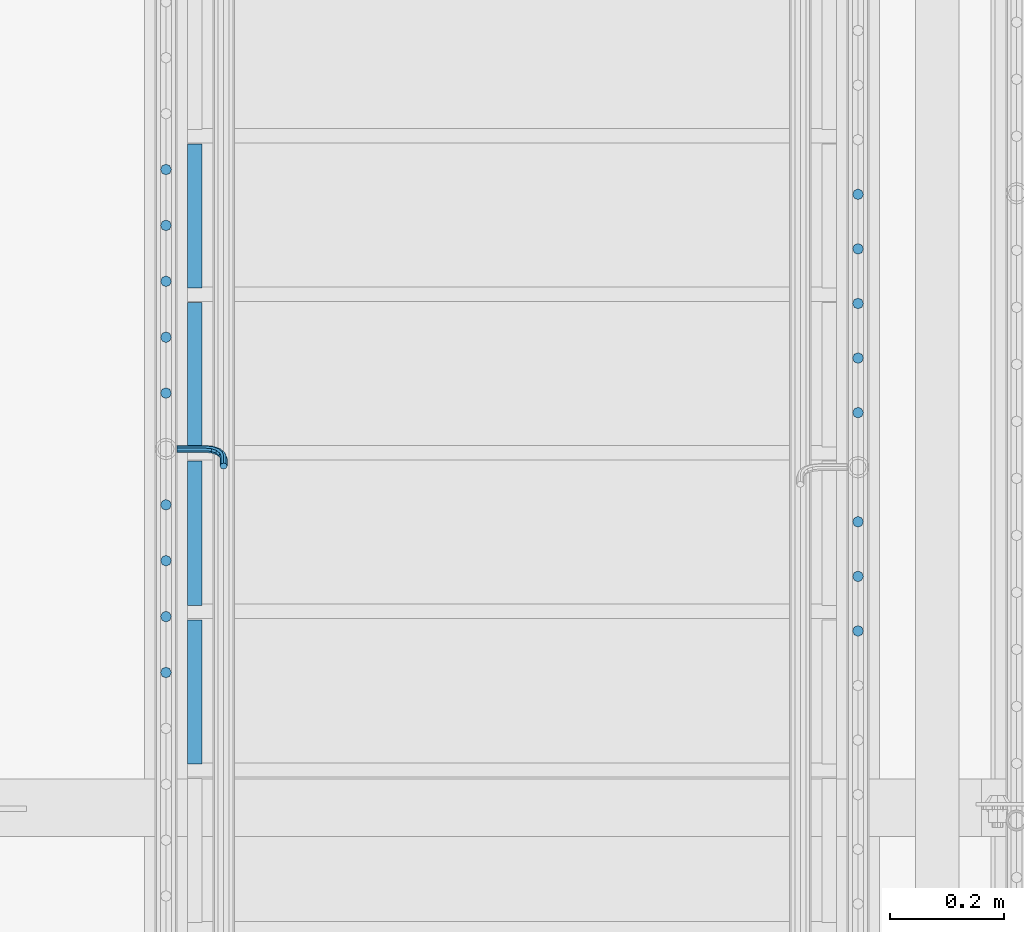
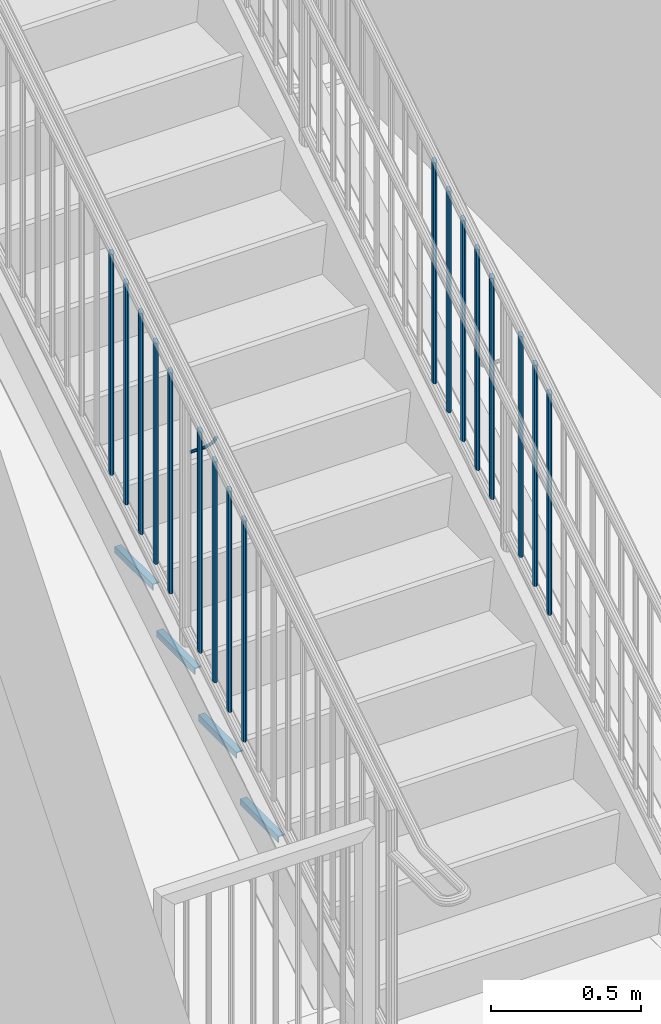
# One storey, part 1266 of 1763: 22 beams, 3 elements without a shape of their own.
"""IFC2X3 building model written with IfcOpenShell, lengths in millimetres."""

from ifc_helpers import new_model, si_unit, frame, origin_with_axes, place, context, subcontext, project, spatial, faceted_brep, material, type_object, element, aggregate, save


model = new_model("IFC2X3")

# Units and contexts
model_context = context("Model", 3, precision=1e-05, world=origin_with_axes())
body_context = subcontext(model_context, "Body", "Model", "MODEL_VIEW")
ifc_project = project(units=[si_unit("LENGTHUNIT", "METRE", prefix="MILLI"), si_unit("AREAUNIT", "SQUARE_METRE"), si_unit("VOLUMEUNIT", "CUBIC_METRE"), si_unit("MASSUNIT", "GRAM", prefix="KILO"), si_unit("TIMEUNIT", "SECOND"), si_unit("PLANEANGLEUNIT", "RADIAN"), si_unit("SOLIDANGLEUNIT", "STERADIAN"), si_unit("THERMODYNAMICTEMPERATUREUNIT", "DEGREE_CELSIUS"), si_unit("LUMINOUSINTENSITYUNIT", "LUMEN")], contexts=[model_context])

# Site, building, storey
site_placement = place(None, origin_with_axes())
site = spatial("IfcSite", under=ifc_project, at=site_placement, CompositionType="ELEMENT")
building_placement = place(site_placement, origin_with_axes())
building = spatial("IfcBuilding", under=site, at=building_placement, Name="Undefined", CompositionType="ELEMENT")
storey_placement = place(building_placement, origin_with_axes())
storey = spatial("IfcBuildingStorey", under=building, at=storey_placement, Name="Undefined", CompositionType="ELEMENT", Elevation=0.0)

# Assembly, beam
assembly_1_placement = place(storey_placement, origin_with_axes())
assembly_1 = element("IfcElementAssembly", 1, at=assembly_1_placement, inside=storey, Name="RAIL", AssemblyPlace="NOTDEFINED", PredefinedType="RIGID_FRAME")
ifc_material = material(Name="STEEL/A36")
beam_type_1 = type_object("IfcBeamType", PredefinedType="NOTDEFINED")
beam_1_placement = place(assembly_1_placement, frame((-86759.4872736811, 33433.1733337026, 2008.49342557848), z_axis=(0.0, -0.849698797869672, -0.527268387919127), x_axis=(1.0, 0.0, 0.0)))
beam_1 = element("IfcBeam", 2, at=beam_1_placement, type_object=beam_type_1, material=ifc_material, Name="RAIL", context=body_context, shape_type="Brep", body=[
    faceted_brep([(0.0, -6.34999999999491, 1.45519152283669e-11), (-1.13686837721616e-13, -4.49012806053361, -4.49012806058454), (50.8000030517578, -4.49012806053452, -4.49012806053361), (50.8000030517578, -6.35000000000036, 0.0), (0.0, 0.0, -6.34999990463257), (50.8000030517578, 0.0, -6.34999999999854), (0.0, 4.49012806054088, -4.49012806053452), (50.8000030517578, 4.49012806053452, -4.49012806053361), (0.0, 6.34999999999491, -2.91038304567337e-11), (50.8000030517578, 6.35000000000036, 0.0), (0.0, 4.49012806054088, 4.49012806053452), (50.8000030517578, 4.49012806053452, 4.49012806053361), (0.0, 0.0, 6.34999990463257), (50.8000030517578, 0.0, 6.34999999999854), (0.0, -4.49012806053361, 4.49012806055543), (50.8000030517578, -4.49012806053452, 4.49012806053361), (65.380241824867, -3.44981018867929, 0.0), (64.6684996473195, -1.73151257071549, 4.49012806053361), (62.9502020293439, 2.4168248427668, 6.34999999999854), (61.2319044113829, 6.5651622562491, 4.49012806053361), (60.5201622338354, 8.2834598742138, 0.0), (61.2319044113829, 6.5651622562491, -4.49012806053361), (62.9502020293439, 2.4168248427668, -6.34999999999854), (64.6684996473195, -1.73151257071549, -4.49012806053361), (76.425643354436, 6.12435969732724, -4.49012806053361), (77.7407714149595, 4.8092316367929, 0.0), (73.2506433544331, 9.29935969732742, -6.34999999999854), (70.0756433544302, 12.4743596973276, -4.49012806053361), (68.7605152938922, 13.7894877578619, 0.0), (70.0756433544302, 12.4743596973276, 4.49012806053361), (73.2506433544331, 9.29935969732742, 6.34999999999854), (76.425643354436, 6.12435969732724, 4.49012806053361), (84.2815156224679, 17.8815034044446, -4.49012806053361), (85.9998132404435, 17.1697612268908, 0.0), (80.1331782089983, 19.5998010224093, -6.34999999999854), (75.9848407955142, 21.3180986403731, -4.49012806053361), (74.2665431775386, 22.0298408179269, 0.0), (75.9848407955142, 21.3180986403731, 4.49012806053361), (80.1331782089983, 19.5998010224093, 6.34999999999854), (84.2815156224679, 17.8815034044446, 4.49012806053361), (87.0401311122987, 31.75, -4.49012806053361), (88.9000030517636, 31.75, 0.0), (82.5500030517578, 31.75, -6.34999999999854), (78.0598749912169, 31.75, -4.49012806053361), (76.200003051752, 31.75, 0.0), (78.0598749912169, 31.75, 4.49012806053361), (82.5500030517578, 31.75, 6.34999999999854), (87.0401311122987, 31.75, 4.49012806053361), (87.0401311122987, 57.1500015258789, -4.49012806053361), (88.9000030517636, 57.1500015258789, 0.0), (82.5500030517578, 57.1500015258789, -6.34999999999854), (78.0598749912169, 57.1500015258789, -4.49012806053361), (76.200003051752, 57.1500015258789, 0.0), (78.0598749912169, 57.1500015258789, 4.49012806053361), (82.5500030517578, 57.1500015258789, 6.34999999999854), (87.0401311122987, 57.1500015258789, 4.49012806053361)], [[[0, 1, 2, 3]], [[1, 4, 5, 2]], [[4, 6, 7, 5]], [[6, 8, 9, 7]], [[8, 10, 11, 9]], [[10, 12, 13, 11]], [[12, 14, 15, 13]], [[14, 0, 3, 15]], [[14, 12, 10, 8, 6, 4, 1, 0]], [[15, 3, 16, 17]], [[13, 15, 17, 18]], [[11, 13, 18, 19]], [[9, 11, 19, 20]], [[7, 9, 20, 21]], [[5, 7, 21, 22]], [[2, 5, 22, 23]], [[3, 2, 23, 16]], [[23, 24, 25, 16]], [[22, 26, 24, 23]], [[21, 27, 26, 22]], [[20, 28, 27, 21]], [[19, 29, 28, 20]], [[18, 30, 29, 19]], [[17, 31, 30, 18]], [[16, 25, 31, 17]], [[24, 32, 33, 25]], [[26, 34, 32, 24]], [[27, 35, 34, 26]], [[28, 36, 35, 27]], [[29, 37, 36, 28]], [[30, 38, 37, 29]], [[31, 39, 38, 30]], [[25, 33, 39, 31]], [[32, 40, 41, 33]], [[34, 42, 40, 32]], [[35, 43, 42, 34]], [[36, 44, 43, 35]], [[37, 45, 44, 36]], [[38, 46, 45, 37]], [[39, 47, 46, 38]], [[33, 41, 47, 39]], [[41, 40, 48, 49]], [[40, 42, 50, 48]], [[42, 43, 51, 50]], [[43, 44, 52, 51]], [[44, 45, 53, 52]], [[45, 46, 54, 53]], [[46, 47, 55, 54]], [[47, 41, 49, 55]], [[50, 51, 52, 53, 54, 55, 49, 48]]]),
])

# Assembly, beams
assembly_2_placement = place(storey_placement, origin_with_axes())
assembly_2 = element("IfcElementAssembly", 3, at=assembly_2_placement, inside=storey, Name="RAIL", AssemblyPlace="NOTDEFINED", PredefinedType="RIGID_FRAME")
beam_type_2 = type_object("IfcBeamType", PredefinedType="NOTDEFINED")
beam_2_placement = place(assembly_2_placement, frame((-85559.3372736932, 33881.7857146562, 2528.95244774683), z_axis=(-1.0, 0.0, 0.0), x_axis=(0.0, 0.0, -1.0)))
beam_2 = element("IfcBeam", 4, at=beam_2_placement, type_object=beam_type_2, material=ifc_material, Name="PICKET", context=body_context, shape_type="Brep", body=[
    faceted_brep([(16.5091072770651, -9.52500000000146, 0.0), (18.2402825153672, -6.73519209080405, -6.73519209079677), (919.550864034841, -6.73519209080405, -6.73519209079677), (917.819688796539, -9.52500000000146, 0.0), (22.4197092545201, 0.0, -9.52499999999418), (923.730290773995, 0.0, -9.52499999999418), (26.5991359936734, 6.73519209080405, -6.73519209079677), (927.909717513148, 6.73519209080405, -6.73519209079677), (28.330311231975, 9.52500000000146, 0.0), (929.64089275145, 9.52500000000146, 0.0), (26.5991359936734, 6.73519209080405, 6.73519209079677), (927.909717513148, 6.73519209080405, 6.73519209079677), (22.4197092545201, 0.0, 9.52499999999418), (923.730290773995, 0.0, 9.52499999999418), (18.2402825153672, -6.73519209080405, 6.73519209079677), (919.550864034841, -6.73519209080405, 6.73519209079677)], [[[0, 1, 2, 3]], [[1, 4, 5, 2]], [[4, 6, 7, 5]], [[6, 8, 9, 7]], [[8, 10, 11, 9]], [[10, 12, 13, 11]], [[12, 14, 15, 13]], [[14, 0, 3, 15]], [[13, 15, 3, 2, 5, 7, 9, 11]], [[14, 12, 10, 8, 6, 4, 1, 0]]]),
])
beam_3_placement = place(assembly_2_placement, frame((-85559.3372736932, 33785.628571799, 2469.28351349763), z_axis=(-1.0, 0.0, 0.0), x_axis=(0.0, 0.0, -1.0)))
beam_3 = element("IfcBeam", 5, at=beam_3_placement, type_object=beam_type_2, material=ifc_material, Name="PICKET", context=body_context, shape_type="Brep", body=[
    faceted_brep([(16.5091072770651, -9.52500000000146, 0.0), (18.2402825153672, -6.73519209080405, -6.73519209079677), (919.550864034841, -6.73519209080405, -6.73519209079677), (917.819688796539, -9.52500000000146, 0.0), (22.4197092545201, 0.0, -9.52499999999418), (923.730290773995, 0.0, -9.52499999999418), (26.5991359936734, 6.73519209080405, -6.73519209079677), (927.909717513148, 6.73519209080405, -6.73519209079677), (28.330311231975, 9.52500000000146, 0.0), (929.64089275145, 9.52500000000146, 0.0), (26.5991359936734, 6.73519209080405, 6.73519209079677), (927.909717513148, 6.73519209080405, 6.73519209079677), (22.4197092545201, 0.0, 9.52499999999418), (923.730290773995, 0.0, 9.52499999999418), (18.2402825153672, -6.73519209080405, 6.73519209079677), (919.550864034841, -6.73519209080405, 6.73519209079677)], [[[0, 1, 2, 3]], [[1, 4, 5, 2]], [[4, 6, 7, 5]], [[6, 8, 9, 7]], [[8, 10, 11, 9]], [[10, 12, 13, 11]], [[12, 14, 15, 13]], [[14, 0, 3, 15]], [[13, 15, 3, 2, 5, 7, 9, 11]], [[14, 12, 10, 8, 6, 4, 1, 0]]]),
])
beam_4_placement = place(assembly_2_placement, frame((-85559.3372736932, 33689.4714289418, 2409.61457924844), z_axis=(-1.0, 0.0, 0.0), x_axis=(0.0, 0.0, -1.0)))
beam_4 = element("IfcBeam", 6, at=beam_4_placement, type_object=beam_type_2, material=ifc_material, Name="PICKET", context=body_context, shape_type="Brep", body=[
    faceted_brep([(16.5091072770651, -9.52500000000146, 0.0), (18.2402825153672, -6.73519209080405, -6.73519209079677), (919.550864034841, -6.73519209080405, -6.73519209079677), (917.819688796539, -9.52500000000146, 0.0), (22.4197092545201, 0.0, -9.52499999999418), (923.730290773995, 0.0, -9.52499999999418), (26.5991359936734, 6.73519209080405, -6.73519209079677), (927.909717513148, 6.73519209080405, -6.73519209079677), (28.330311231975, 9.52500000000146, 0.0), (929.64089275145, 9.52500000000146, 0.0), (26.5991359936734, 6.73519209080405, 6.73519209079677), (927.909717513148, 6.73519209080405, 6.73519209079677), (22.4197092545201, 0.0, 9.52499999999418), (923.730290773995, 0.0, 9.52499999999418), (18.2402825153672, -6.73519209080405, 6.73519209079677), (919.550864034841, -6.73519209080405, 6.73519209079677)], [[[0, 1, 2, 3]], [[1, 4, 5, 2]], [[4, 6, 7, 5]], [[6, 8, 9, 7]], [[8, 10, 11, 9]], [[10, 12, 13, 11]], [[12, 14, 15, 13]], [[14, 0, 3, 15]], [[13, 15, 3, 2, 5, 7, 9, 11]], [[14, 12, 10, 8, 6, 4, 1, 0]]]),
])
beam_5_placement = place(assembly_2_placement, frame((-85559.3372736932, 33593.3142860846, 2349.94564499924), z_axis=(-1.0, 0.0, 0.0), x_axis=(0.0, 0.0, -1.0)))
beam_5 = element("IfcBeam", 7, at=beam_5_placement, type_object=beam_type_2, material=ifc_material, Name="PICKET", context=body_context, shape_type="Brep", body=[
    faceted_brep([(16.5091072770651, -9.52500000000146, 0.0), (18.2402825153672, -6.73519209080405, -6.73519209079677), (919.550864034841, -6.73519209080405, -6.73519209079677), (917.819688796539, -9.52500000000146, 0.0), (22.4197092545201, 0.0, -9.52499999999418), (923.730290773995, 0.0, -9.52499999999418), (26.5991359936734, 6.73519209080405, -6.73519209079677), (927.909717513148, 6.73519209080405, -6.73519209079677), (28.330311231975, 9.52500000000146, 0.0), (929.64089275145, 9.52500000000146, 0.0), (26.5991359936734, 6.73519209080405, 6.73519209079677), (927.909717513148, 6.73519209080405, 6.73519209079677), (22.4197092545201, 0.0, 9.52499999999418), (923.730290773995, 0.0, 9.52499999999418), (18.2402825153672, -6.73519209080405, 6.73519209079677), (919.550864034841, -6.73519209080405, 6.73519209079677)], [[[0, 1, 2, 3]], [[1, 4, 5, 2]], [[4, 6, 7, 5]], [[6, 8, 9, 7]], [[8, 10, 11, 9]], [[10, 12, 13, 11]], [[12, 14, 15, 13]], [[14, 0, 3, 15]], [[13, 15, 3, 2, 5, 7, 9, 11]], [[14, 12, 10, 8, 6, 4, 1, 0]]]),
])
beam_6_placement = place(assembly_2_placement, frame((-85559.3372736932, 33497.1571432274, 2290.27671075005), z_axis=(-1.0, 0.0, 0.0), x_axis=(0.0, 0.0, -1.0)))
beam_6 = element("IfcBeam", 8, at=beam_6_placement, type_object=beam_type_2, material=ifc_material, Name="PICKET", context=body_context, shape_type="Brep", body=[
    faceted_brep([(16.5091072770651, -9.52500000000146, 0.0), (18.2402825153672, -6.73519209080405, -6.73519209079677), (919.550864034841, -6.73519209080405, -6.73519209079677), (917.819688796539, -9.52500000000146, 0.0), (22.4197092545201, 0.0, -9.52499999999418), (923.730290773995, 0.0, -9.52499999999418), (26.5991359936734, 6.73519209080405, -6.73519209079677), (927.909717513148, 6.73519209080405, -6.73519209079677), (28.330311231975, 9.52500000000146, 0.0), (929.64089275145, 9.52500000000146, 0.0), (26.5991359936734, 6.73519209080405, 6.73519209079677), (927.909717513148, 6.73519209080405, 6.73519209079677), (22.4197092545201, 0.0, 9.52499999999418), (923.730290773995, 0.0, 9.52499999999418), (18.2402825153672, -6.73519209080405, 6.73519209079677), (919.550864034841, -6.73519209080405, 6.73519209079677)], [[[0, 1, 2, 3]], [[1, 4, 5, 2]], [[4, 6, 7, 5]], [[6, 8, 9, 7]], [[8, 10, 11, 9]], [[10, 12, 13, 11]], [[12, 14, 15, 13]], [[14, 0, 3, 15]], [[13, 15, 3, 2, 5, 7, 9, 11]], [[14, 12, 10, 8, 6, 4, 1, 0]]]),
])
beam_7_placement = place(assembly_2_placement, frame((-85559.3372736932, 33304.842857513, 2170.93884225261), z_axis=(-1.0, 0.0, 0.0), x_axis=(0.0, 0.0, -1.0)))
beam_7 = element("IfcBeam", 9, at=beam_7_placement, type_object=beam_type_2, material=ifc_material, Name="PICKET", context=body_context, shape_type="Brep", body=[
    faceted_brep([(16.5091072770651, -9.52500000000146, 0.0), (18.2402825153672, -6.73519209080405, -6.73519209079677), (919.550864034841, -6.73519209080405, -6.73519209079677), (917.819688796539, -9.52500000000146, 0.0), (22.4197092545201, 0.0, -9.52499999999418), (923.730290773995, 0.0, -9.52499999999418), (26.5991359936734, 6.73519209080405, -6.73519209079677), (927.909717513148, 6.73519209080405, -6.73519209079677), (28.330311231975, 9.52500000000146, 0.0), (929.64089275145, 9.52500000000146, 0.0), (26.5991359936734, 6.73519209080405, 6.73519209079677), (927.909717513148, 6.73519209080405, 6.73519209079677), (22.4197092545201, 0.0, 9.52499999999418), (923.730290773995, 0.0, 9.52499999999418), (18.2402825153672, -6.73519209080405, 6.73519209079677), (919.550864034841, -6.73519209080405, 6.73519209079677)], [[[0, 1, 2, 3]], [[1, 4, 5, 2]], [[4, 6, 7, 5]], [[6, 8, 9, 7]], [[8, 10, 11, 9]], [[10, 12, 13, 11]], [[12, 14, 15, 13]], [[14, 0, 3, 15]], [[13, 15, 3, 2, 5, 7, 9, 11]], [[14, 12, 10, 8, 6, 4, 1, 0]]]),
])
beam_8_placement = place(assembly_2_placement, frame((-85559.3372736932, 33208.6857146558, 2111.26990800437), z_axis=(-1.0, 0.0, 0.0), x_axis=(0.0, 0.0, -1.0)))
beam_8 = element("IfcBeam", 10, at=beam_8_placement, type_object=beam_type_2, material=ifc_material, Name="PICKET", context=body_context, shape_type="Brep", body=[
    faceted_brep([(16.5091072770651, -9.52500000000146, 0.0), (18.2402825153672, -6.73519209080405, -6.73519209079677), (919.550864034841, -6.73519209080405, -6.73519209079677), (917.819688796539, -9.52500000000146, 0.0), (22.4197092545201, 0.0, -9.52499999999418), (923.730290773995, 0.0, -9.52499999999418), (26.5991359936734, 6.73519209080405, -6.73519209079677), (927.909717513148, 6.73519209080405, -6.73519209079677), (28.330311231975, 9.52500000000146, 0.0), (929.64089275145, 9.52500000000146, 0.0), (26.5991359936734, 6.73519209080405, 6.73519209079677), (927.909717513148, 6.73519209080405, 6.73519209079677), (22.4197092545201, 0.0, 9.52499999999418), (923.730290773995, 0.0, 9.52499999999418), (18.2402825153672, -6.73519209080405, 6.73519209079677), (919.550864034841, -6.73519209080405, 6.73519209079677)], [[[0, 1, 2, 3]], [[1, 4, 5, 2]], [[4, 6, 7, 5]], [[6, 8, 9, 7]], [[8, 10, 11, 9]], [[10, 12, 13, 11]], [[12, 14, 15, 13]], [[14, 0, 3, 15]], [[13, 15, 3, 2, 5, 7, 9, 11]], [[14, 12, 10, 8, 6, 4, 1, 0]]]),
])
beam_9_placement = place(assembly_2_placement, frame((-85559.3372736932, 33112.5285717986, 2051.60097375612), z_axis=(-1.0, 0.0, 0.0), x_axis=(0.0, 0.0, -1.0)))
beam_9 = element("IfcBeam", 11, at=beam_9_placement, type_object=beam_type_2, material=ifc_material, Name="PICKET", context=body_context, shape_type="Brep", body=[
    faceted_brep([(16.5091072770651, -9.52500000000146, 0.0), (18.2402825153672, -6.73519209080405, -6.73519209079677), (919.550864034841, -6.73519209080405, -6.73519209079677), (917.819688796539, -9.52500000000146, 0.0), (22.4197092545201, 0.0, -9.52499999999418), (923.730290773995, 0.0, -9.52499999999418), (26.5991359936734, 6.73519209080405, -6.73519209079677), (927.909717513148, 6.73519209080405, -6.73519209079677), (28.330311231975, 9.52500000000146, 0.0), (929.64089275145, 9.52500000000146, 0.0), (26.5991359936734, 6.73519209080405, 6.73519209079677), (927.909717513148, 6.73519209080405, 6.73519209079677), (22.4197092545201, 0.0, 9.52499999999418), (923.730290773995, 0.0, 9.52499999999418), (18.2402825153672, -6.73519209080405, 6.73519209079677), (919.550864034841, -6.73519209080405, 6.73519209079677)], [[[0, 1, 2, 3]], [[1, 4, 5, 2]], [[4, 6, 7, 5]], [[6, 8, 9, 7]], [[8, 10, 11, 9]], [[10, 12, 13, 11]], [[12, 14, 15, 13]], [[14, 0, 3, 15]], [[13, 15, 3, 2, 5, 7, 9, 11]], [[14, 12, 10, 8, 6, 4, 1, 0]]]),
])
aggregate(assembly_2, [beam_2, beam_3, beam_4, beam_5, beam_6, beam_7, beam_8, beam_9])

# Beam
beam_10_placement = place(assembly_1_placement, frame((-86778.5372736927, 33925.4495241788, 2556.04739776176), z_axis=(-1.0, 0.0, 0.0), x_axis=(0.0, 0.0, -1.0)))
beam_10 = element("IfcBeam", 12, at=beam_10_placement, type_object=beam_type_2, material=ifc_material, Name="PICKET", context=body_context, shape_type="Brep", body=[
    faceted_brep([(16.5091072770651, -9.52500000000146, 0.0), (18.2402825153672, -6.73519209080405, -6.73519209079677), (919.550864034841, -6.73519209080405, -6.73519209079677), (917.819688796539, -9.52500000000146, 0.0), (22.4197092545201, 0.0, -9.52499999999418), (923.730290773995, 0.0, -9.52499999999418), (26.5991359936734, 6.73519209080405, -6.73519209079677), (927.909717513148, 6.73519209080405, -6.73519209079677), (28.330311231975, 9.52500000000146, 0.0), (929.64089275145, 9.52500000000146, 0.0), (26.5991359936734, 6.73519209080405, 6.73519209079677), (927.909717513148, 6.73519209080405, 6.73519209079677), (22.4197092545201, 0.0, 9.52499999999418), (923.730290773995, 0.0, 9.52499999999418), (18.2402825153672, -6.73519209080405, 6.73519209079677), (919.550864034841, -6.73519209080405, 6.73519209079677)], [[[0, 1, 2, 3]], [[1, 4, 5, 2]], [[4, 6, 7, 5]], [[6, 8, 9, 7]], [[8, 10, 11, 9]], [[10, 12, 13, 11]], [[12, 14, 15, 13]], [[14, 0, 3, 15]], [[13, 15, 3, 2, 5, 7, 9, 11]], [[14, 12, 10, 8, 6, 4, 1, 0]]]),
])

beam_11_placement = place(assembly_1_placement, frame((-86778.5372736927, 33826.9942860836, 2494.95241351203), z_axis=(-1.0, 0.0, 0.0), x_axis=(0.0, 0.0, -1.0)))
beam_11 = element("IfcBeam", 13, at=beam_11_placement, type_object=beam_type_2, material=ifc_material, Name="PICKET", context=body_context, shape_type="Brep", body=[
    faceted_brep([(16.5091072770651, -9.52500000000146, 0.0), (18.2402825153672, -6.73519209080405, -6.73519209079677), (919.550864034841, -6.73519209080405, -6.73519209079677), (917.819688796539, -9.52500000000146, 0.0), (22.4197092545201, 0.0, -9.52499999999418), (923.730290773995, 0.0, -9.52499999999418), (26.5991359936734, 6.73519209080405, -6.73519209079677), (927.909717513148, 6.73519209080405, -6.73519209079677), (28.330311231975, 9.52500000000146, 0.0), (929.64089275145, 9.52500000000146, 0.0), (26.5991359936734, 6.73519209080405, 6.73519209079677), (927.909717513148, 6.73519209080405, 6.73519209079677), (22.4197092545201, 0.0, 9.52499999999418), (923.730290773995, 0.0, 9.52499999999418), (18.2402825153672, -6.73519209080405, 6.73519209079677), (919.550864034841, -6.73519209080405, 6.73519209079677)], [[[0, 1, 2, 3]], [[1, 4, 5, 2]], [[4, 6, 7, 5]], [[6, 8, 9, 7]], [[8, 10, 11, 9]], [[10, 12, 13, 11]], [[12, 14, 15, 13]], [[14, 0, 3, 15]], [[13, 15, 3, 2, 5, 7, 9, 11]], [[14, 12, 10, 8, 6, 4, 1, 0]]]),
])

beam_12_placement = place(assembly_1_placement, frame((-86778.5372736927, 33728.5390479883, 2433.8574292623), z_axis=(-1.0, 0.0, 0.0), x_axis=(0.0, 0.0, -1.0)))
beam_12 = element("IfcBeam", 14, at=beam_12_placement, type_object=beam_type_2, material=ifc_material, Name="PICKET", context=body_context, shape_type="Brep", body=[
    faceted_brep([(16.5091072770651, -9.52500000000146, 0.0), (18.2402825153672, -6.73519209080405, -6.73519209079677), (919.550864034841, -6.73519209080405, -6.73519209079677), (917.819688796539, -9.52500000000146, 0.0), (22.4197092545201, 0.0, -9.52499999999418), (923.730290773995, 0.0, -9.52499999999418), (26.5991359936734, 6.73519209080405, -6.73519209079677), (927.909717513148, 6.73519209080405, -6.73519209079677), (28.330311231975, 9.52500000000146, 0.0), (929.64089275145, 9.52500000000146, 0.0), (26.5991359936734, 6.73519209080405, 6.73519209079677), (927.909717513148, 6.73519209080405, 6.73519209079677), (22.4197092545201, 0.0, 9.52499999999418), (923.730290773995, 0.0, 9.52499999999418), (18.2402825153672, -6.73519209080405, 6.73519209079677), (919.550864034841, -6.73519209080405, 6.73519209079677)], [[[0, 1, 2, 3]], [[1, 4, 5, 2]], [[4, 6, 7, 5]], [[6, 8, 9, 7]], [[8, 10, 11, 9]], [[10, 12, 13, 11]], [[12, 14, 15, 13]], [[14, 0, 3, 15]], [[13, 15, 3, 2, 5, 7, 9, 11]], [[14, 12, 10, 8, 6, 4, 1, 0]]]),
])

beam_13_placement = place(assembly_1_placement, frame((-86778.5372736927, 33630.0838098931, 2372.76244501257), z_axis=(-1.0, 0.0, 0.0), x_axis=(0.0, 0.0, -1.0)))
beam_13 = element("IfcBeam", 15, at=beam_13_placement, type_object=beam_type_2, material=ifc_material, Name="PICKET", context=body_context, shape_type="Brep", body=[
    faceted_brep([(16.5091072770651, -9.52500000000146, 0.0), (18.2402825153672, -6.73519209080405, -6.73519209079677), (919.550864034841, -6.73519209080405, -6.73519209079677), (917.819688796539, -9.52500000000146, 0.0), (22.4197092545201, 0.0, -9.52499999999418), (923.730290773995, 0.0, -9.52499999999418), (26.5991359936734, 6.73519209080405, -6.73519209079677), (927.909717513148, 6.73519209080405, -6.73519209079677), (28.330311231975, 9.52500000000146, 0.0), (929.64089275145, 9.52500000000146, 0.0), (26.5991359936734, 6.73519209080405, 6.73519209079677), (927.909717513148, 6.73519209080405, 6.73519209079677), (22.4197092545201, 0.0, 9.52499999999418), (923.730290773995, 0.0, 9.52499999999418), (18.2402825153672, -6.73519209080405, 6.73519209079677), (919.550864034841, -6.73519209080405, 6.73519209079677)], [[[0, 1, 2, 3]], [[1, 4, 5, 2]], [[4, 6, 7, 5]], [[6, 8, 9, 7]], [[8, 10, 11, 9]], [[10, 12, 13, 11]], [[12, 14, 15, 13]], [[14, 0, 3, 15]], [[13, 15, 3, 2, 5, 7, 9, 11]], [[14, 12, 10, 8, 6, 4, 1, 0]]]),
])

beam_14_placement = place(assembly_1_placement, frame((-86778.5372736927, 33531.6285717979, 2311.66746076284), z_axis=(-1.0, 0.0, 0.0), x_axis=(0.0, 0.0, -1.0)))
beam_14 = element("IfcBeam", 16, at=beam_14_placement, type_object=beam_type_2, material=ifc_material, Name="PICKET", context=body_context, shape_type="Brep", body=[
    faceted_brep([(16.5091072770651, -9.52500000000146, 0.0), (18.2402825153672, -6.73519209080405, -6.73519209079677), (919.550864034841, -6.73519209080405, -6.73519209079677), (917.819688796539, -9.52500000000146, 0.0), (22.4197092545201, 0.0, -9.52499999999418), (923.730290773995, 0.0, -9.52499999999418), (26.5991359936734, 6.73519209080405, -6.73519209079677), (927.909717513148, 6.73519209080405, -6.73519209079677), (28.330311231975, 9.52500000000146, 0.0), (929.64089275145, 9.52500000000146, 0.0), (26.5991359936734, 6.73519209080405, 6.73519209079677), (927.909717513148, 6.73519209080405, 6.73519209079677), (22.4197092545201, 0.0, 9.52499999999418), (923.730290773995, 0.0, 9.52499999999418), (18.2402825153672, -6.73519209080405, 6.73519209079677), (919.550864034841, -6.73519209080405, 6.73519209079677)], [[[0, 1, 2, 3]], [[1, 4, 5, 2]], [[4, 6, 7, 5]], [[6, 8, 9, 7]], [[8, 10, 11, 9]], [[10, 12, 13, 11]], [[12, 14, 15, 13]], [[14, 0, 3, 15]], [[13, 15, 3, 2, 5, 7, 9, 11]], [[14, 12, 10, 8, 6, 4, 1, 0]]]),
])

beam_15_placement = place(assembly_1_placement, frame((-86778.5372736927, 33334.7180956074, 2189.47749226399), z_axis=(-1.0, 0.0, 0.0), x_axis=(0.0, 0.0, -1.0)))
beam_15 = element("IfcBeam", 17, at=beam_15_placement, type_object=beam_type_2, material=ifc_material, Name="PICKET", context=body_context, shape_type="Brep", body=[
    faceted_brep([(16.5091072770651, -9.52500000000146, 0.0), (18.2402825153672, -6.73519209080405, -6.73519209079677), (919.550864034841, -6.73519209080405, -6.73519209079677), (917.819688796539, -9.52500000000146, 0.0), (22.4197092545201, 0.0, -9.52499999999418), (923.730290773995, 0.0, -9.52499999999418), (26.5991359936734, 6.73519209080405, -6.73519209079677), (927.909717513148, 6.73519209080405, -6.73519209079677), (28.330311231975, 9.52500000000146, 0.0), (929.64089275145, 9.52500000000146, 0.0), (26.5991359936734, 6.73519209080405, 6.73519209079677), (927.909717513148, 6.73519209080405, 6.73519209079677), (22.4197092545201, 0.0, 9.52499999999418), (923.730290773995, 0.0, 9.52499999999418), (18.2402825153672, -6.73519209080405, 6.73519209079677), (919.550864034841, -6.73519209080405, 6.73519209079677)], [[[0, 1, 2, 3]], [[1, 4, 5, 2]], [[4, 6, 7, 5]], [[6, 8, 9, 7]], [[8, 10, 11, 9]], [[10, 12, 13, 11]], [[12, 14, 15, 13]], [[14, 0, 3, 15]], [[13, 15, 3, 2, 5, 7, 9, 11]], [[14, 12, 10, 8, 6, 4, 1, 0]]]),
])

beam_16_placement = place(assembly_1_placement, frame((-86778.5372736927, 33236.2628575121, 2128.38250801488), z_axis=(-1.0, 0.0, 0.0), x_axis=(0.0, 0.0, -1.0)))
beam_16 = element("IfcBeam", 18, at=beam_16_placement, type_object=beam_type_2, material=ifc_material, Name="PICKET", context=body_context, shape_type="Brep", body=[
    faceted_brep([(16.5091072770651, -9.52500000000146, 0.0), (18.2402825153672, -6.73519209080405, -6.73519209079677), (919.550864034841, -6.73519209080405, -6.73519209079677), (917.819688796539, -9.52500000000146, 0.0), (22.4197092545201, 0.0, -9.52499999999418), (923.730290773995, 0.0, -9.52499999999418), (26.5991359936734, 6.73519209080405, -6.73519209079677), (927.909717513148, 6.73519209080405, -6.73519209079677), (28.330311231975, 9.52500000000146, 0.0), (929.64089275145, 9.52500000000146, 0.0), (26.5991359936734, 6.73519209080405, 6.73519209079677), (927.909717513148, 6.73519209080405, 6.73519209079677), (22.4197092545201, 0.0, 9.52499999999418), (923.730290773995, 0.0, 9.52499999999418), (18.2402825153672, -6.73519209080405, 6.73519209079677), (919.550864034841, -6.73519209080405, 6.73519209079677)], [[[0, 1, 2, 3]], [[1, 4, 5, 2]], [[4, 6, 7, 5]], [[6, 8, 9, 7]], [[8, 10, 11, 9]], [[10, 12, 13, 11]], [[12, 14, 15, 13]], [[14, 0, 3, 15]], [[13, 15, 3, 2, 5, 7, 9, 11]], [[14, 12, 10, 8, 6, 4, 1, 0]]]),
])

beam_17_placement = place(assembly_1_placement, frame((-86778.5372736927, 33137.8076194169, 2067.28752376576), z_axis=(-1.0, 0.0, 0.0), x_axis=(0.0, 0.0, -1.0)))
beam_17 = element("IfcBeam", 19, at=beam_17_placement, type_object=beam_type_2, material=ifc_material, Name="PICKET", context=body_context, shape_type="Brep", body=[
    faceted_brep([(16.5091072770651, -9.52500000000146, 0.0), (18.2402825153672, -6.73519209080405, -6.73519209079677), (919.550864034841, -6.73519209080405, -6.73519209079677), (917.819688796539, -9.52500000000146, 0.0), (22.4197092545201, 0.0, -9.52499999999418), (923.730290773995, 0.0, -9.52499999999418), (26.5991359936734, 6.73519209080405, -6.73519209079677), (927.909717513148, 6.73519209080405, -6.73519209079677), (28.330311231975, 9.52500000000146, 0.0), (929.64089275145, 9.52500000000146, 0.0), (26.5991359936734, 6.73519209080405, 6.73519209079677), (927.909717513148, 6.73519209080405, 6.73519209079677), (22.4197092545201, 0.0, 9.52499999999418), (923.730290773995, 0.0, 9.52499999999418), (18.2402825153672, -6.73519209080405, 6.73519209079677), (919.550864034841, -6.73519209080405, 6.73519209079677)], [[[0, 1, 2, 3]], [[1, 4, 5, 2]], [[4, 6, 7, 5]], [[6, 8, 9, 7]], [[8, 10, 11, 9]], [[10, 12, 13, 11]], [[12, 14, 15, 13]], [[14, 0, 3, 15]], [[13, 15, 3, 2, 5, 7, 9, 11]], [[14, 12, 10, 8, 6, 4, 1, 0]]]),
])

beam_18_placement = place(assembly_1_placement, frame((-86778.5372736927, 33039.3523813217, 2006.19253951664), z_axis=(-1.0, 0.0, 0.0), x_axis=(0.0, 0.0, -1.0)))
beam_18 = element("IfcBeam", 20, at=beam_18_placement, type_object=beam_type_2, material=ifc_material, Name="PICKET", context=body_context, shape_type="Brep", body=[
    faceted_brep([(16.5091072770651, -9.52500000000146, 0.0), (18.2402825153672, -6.73519209080405, -6.73519209079677), (919.550864034841, -6.73519209080405, -6.73519209079677), (917.819688796539, -9.52500000000146, 0.0), (22.4197092545201, 0.0, -9.52499999999418), (923.730290773995, 0.0, -9.52499999999418), (26.5991359936734, 6.73519209080405, -6.73519209079677), (927.909717513148, 6.73519209080405, -6.73519209079677), (28.330311231975, 9.52500000000146, 0.0), (929.64089275145, 9.52500000000146, 0.0), (26.5991359936734, 6.73519209080405, 6.73519209079677), (927.909717513148, 6.73519209080405, 6.73519209079677), (22.4197092545201, 0.0, 9.52499999999418), (923.730290773995, 0.0, 9.52499999999418), (18.2402825153672, -6.73519209080405, 6.73519209079677), (919.550864034841, -6.73519209080405, 6.73519209079677)], [[[0, 1, 2, 3]], [[1, 4, 5, 2]], [[4, 6, 7, 5]], [[6, 8, 9, 7]], [[8, 10, 11, 9]], [[10, 12, 13, 11]], [[12, 14, 15, 13]], [[14, 0, 3, 15]], [[13, 15, 3, 2, 5, 7, 9, 11]], [[14, 12, 10, 8, 6, 4, 1, 0]]]),
])

aggregate(assembly_1, [beam_10, beam_11, beam_12, beam_13, beam_14, beam_15, beam_16, beam_17, beam_18, beam_1])

# Assembly, beams
assembly_3_placement = place(storey_placement, origin_with_axes())
assembly_3 = element("IfcElementAssembly", 21, at=assembly_3_placement, inside=storey, Name="STRINGER", AssemblyPlace="NOTDEFINED", PredefinedType="RIGID_FRAME")
beam_type_3 = type_object("IfcBeamType", Name="L1X1X1/8", PredefinedType="NOTDEFINED")
beam_19_placement = place(assembly_3_placement, frame((-86727.7372739122, 33716.4511407179, 1278.39107161915), z_axis=(1.0, 0.0, 0.0), x_axis=(0.0, 1.0, 0.0)))
beam_19 = element("IfcBeam", 22, at=beam_19_placement, type_object=beam_type_3, material=ifc_material, Name="ANGLE", ObjectType="L1X1X1/8", context=body_context, shape_type="Brep", body=[
    faceted_brep([(3.93434019839663e-12, 12.6999999999978, -12.6999998092651), (-1.31614667686587e-12, 12.6999999999978, 12.6999998092651), (254.0, 12.69999981, 12.6999998099927), (254.0, 12.69999981, -12.6999998099927), (-1.06936913171421e-12, 9.52499999999854, 12.699999332428), (254.0, 9.52499985799977, 12.6999998099927), (0.0, 9.52499985799977, -9.52499985799659), (254.0, 9.52499985799977, -9.52499985799659), (0.0, -12.69999981, -9.52499985799659), (254.0, -12.69999981, -9.52499985799659), (0.0, -12.69999981, -12.6999998099927), (254.0, -12.69999981, -12.6999998099927)], [[[0, 1, 2, 3]], [[1, 4, 5, 2]], [[4, 6, 7, 5]], [[6, 8, 9, 7]], [[8, 10, 11, 9]], [[10, 0, 3, 11]], [[5, 7, 9, 11, 3, 2]], [[10, 8, 6, 4, 1, 0]]]),
])
beam_20_placement = place(assembly_3_placement, frame((-86727.7372739122, 33437.0511407179, 1105.01339304772), z_axis=(1.0, 0.0, 0.0), x_axis=(0.0, 1.0, 0.0)))
beam_20 = element("IfcBeam", 23, at=beam_20_placement, type_object=beam_type_3, material=ifc_material, Name="ANGLE", ObjectType="L1X1X1/8", context=body_context, shape_type="Brep", body=[
    faceted_brep([(3.93434019839663e-12, 12.6999999999978, -12.6999998092651), (-1.31614667686587e-12, 12.6999999999978, 12.6999998092651), (254.0, 12.69999981, 12.6999998099927), (254.0, 12.69999981, -12.6999998099927), (-1.06936913171421e-12, 9.52499999999854, 12.699999332428), (254.0, 9.52499985799977, 12.6999998099927), (0.0, 9.52499985799977, -9.52499985799659), (254.0, 9.52499985799977, -9.52499985799659), (0.0, -12.69999981, -9.52499985799659), (254.0, -12.69999981, -9.52499985799659), (0.0, -12.69999981, -12.6999998099927), (254.0, -12.69999981, -12.6999998099927)], [[[0, 1, 2, 3]], [[1, 4, 5, 2]], [[4, 6, 7, 5]], [[6, 8, 9, 7]], [[8, 10, 11, 9]], [[10, 0, 3, 11]], [[5, 7, 9, 11, 3, 2]], [[10, 8, 6, 4, 1, 0]]]),
])
beam_21_placement = place(assembly_3_placement, frame((-86727.7372739122, 33157.6511407179, 931.635714476291), z_axis=(1.0, 0.0, 0.0), x_axis=(0.0, 1.0, 0.0)))
beam_21 = element("IfcBeam", 24, at=beam_21_placement, type_object=beam_type_3, material=ifc_material, Name="ANGLE", ObjectType="L1X1X1/8", context=body_context, shape_type="Brep", body=[
    faceted_brep([(3.93434019839663e-12, 12.6999999999978, -12.6999998092651), (-1.31614667686587e-12, 12.6999999999978, 12.6999998092651), (254.0, 12.69999981, 12.6999998099927), (254.0, 12.69999981, -12.6999998099927), (-1.06936913171421e-12, 9.52499999999854, 12.699999332428), (254.0, 9.52499985799977, 12.6999998099927), (0.0, 9.52499985799977, -9.52499985799659), (254.0, 9.52499985799977, -9.52499985799659), (0.0, -12.69999981, -9.52499985799659), (254.0, -12.69999981, -9.52499985799659), (0.0, -12.69999981, -12.6999998099927), (254.0, -12.69999981, -12.6999998099927)], [[[0, 1, 2, 3]], [[1, 4, 5, 2]], [[4, 6, 7, 5]], [[6, 8, 9, 7]], [[8, 10, 11, 9]], [[10, 0, 3, 11]], [[5, 7, 9, 11, 3, 2]], [[10, 8, 6, 4, 1, 0]]]),
])
beam_22_placement = place(assembly_3_placement, frame((-86727.7372739122, 32878.2511407179, 758.258035904862), z_axis=(1.0, 0.0, 0.0), x_axis=(0.0, 1.0, 0.0)))
beam_22 = element("IfcBeam", 25, at=beam_22_placement, type_object=beam_type_3, material=ifc_material, Name="ANGLE", ObjectType="L1X1X1/8", context=body_context, shape_type="Brep", body=[
    faceted_brep([(3.93434019839663e-12, 12.6999999999978, -12.6999998092651), (-1.31614667686587e-12, 12.6999999999978, 12.6999998092651), (254.0, 12.69999981, 12.6999998099927), (254.0, 12.69999981, -12.6999998099927), (-1.06936913171421e-12, 9.52499999999854, 12.699999332428), (254.0, 9.52499985799977, 12.6999998099927), (0.0, 9.52499985799977, -9.52499985799659), (254.0, 9.52499985799977, -9.52499985799659), (0.0, -12.69999981, -9.52499985799659), (254.0, -12.69999981, -9.52499985799659), (0.0, -12.69999981, -12.6999998099927), (254.0, -12.69999981, -12.6999998099927)], [[[0, 1, 2, 3]], [[1, 4, 5, 2]], [[4, 6, 7, 5]], [[6, 8, 9, 7]], [[8, 10, 11, 9]], [[10, 0, 3, 11]], [[5, 7, 9, 11, 3, 2]], [[10, 8, 6, 4, 1, 0]]]),
])
aggregate(assembly_3, [beam_19, beam_20, beam_21, beam_22])

save(model, "model.ifc")
